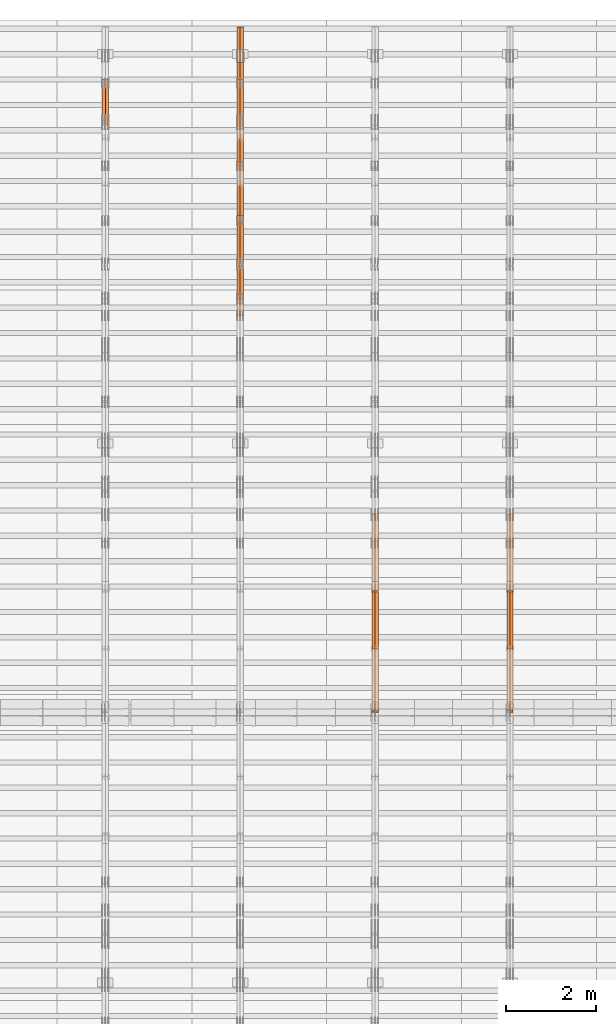
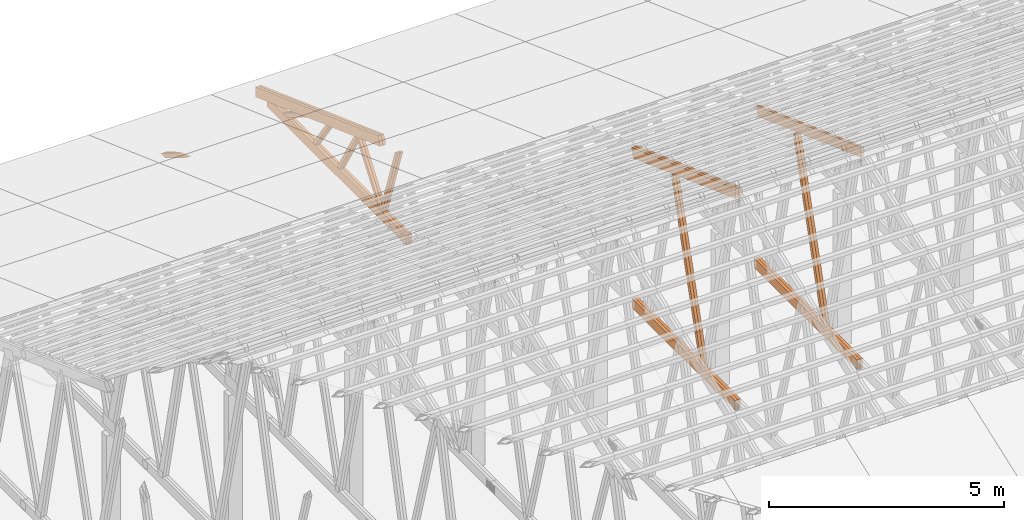
# One storey, part 37 of 189: 27 proxies.
"""IFC2X3 building model written with IfcOpenShell, lengths in millimetres."""

from ifc_helpers import new_model, entity, si_unit, converted_unit, derived_unit, direction, frame, origin, origin_2d_with_axis, place, context, subcontext, project, spatial, polyline, rectangle, outline, extrude, source, transform, mapped, material, type_object, type_shapes, element, save


model = new_model("IFC2X3")

# Units and contexts
model_context = context("Model", 3, precision=0.01, world=origin(), true_north=direction((6.12303176911189e-17, 1.0)))
body_context = subcontext(model_context, "Body", "Model", "MODEL_VIEW")
ifc_project = project(units=[si_unit("LENGTHUNIT", "METRE", prefix="MILLI"), si_unit("AREAUNIT", "SQUARE_METRE"), si_unit("VOLUMEUNIT", "CUBIC_METRE"), converted_unit("PLANEANGLEUNIT", "DEGREE", entity("IfcRatioMeasure", 0.0174532925199433), si_unit("PLANEANGLEUNIT", "RADIAN"), dimensions=[0, 0, 0, 0, 0, 0, 0]), si_unit("MASSUNIT", "GRAM", prefix="KILO"), derived_unit("MASSDENSITYUNIT", [(si_unit("MASSUNIT", "GRAM", prefix="KILO"), 1), (si_unit("LENGTHUNIT", "METRE"), -3)]), si_unit("TIMEUNIT", "SECOND"), si_unit("FREQUENCYUNIT", "HERTZ"), si_unit("THERMODYNAMICTEMPERATUREUNIT", "DEGREE_CELSIUS"), derived_unit("THERMALTRANSMITTANCEUNIT", [(si_unit("MASSUNIT", "GRAM", prefix="KILO"), 1), (si_unit("THERMODYNAMICTEMPERATUREUNIT", "KELVIN"), -1), (si_unit("TIMEUNIT", "SECOND"), -3)]), derived_unit("VOLUMETRICFLOWRATEUNIT", [(si_unit("LENGTHUNIT", "METRE"), 3), (si_unit("TIMEUNIT", "SECOND"), -1)]), si_unit("ELECTRICCURRENTUNIT", "AMPERE"), si_unit("ELECTRICVOLTAGEUNIT", "VOLT"), si_unit("POWERUNIT", "WATT"), si_unit("FORCEUNIT", "NEWTON"), si_unit("ILLUMINANCEUNIT", "LUX"), si_unit("LUMINOUSFLUXUNIT", "LUMEN"), si_unit("LUMINOUSINTENSITYUNIT", "CANDELA"), derived_unit("USERDEFINED", [(si_unit("MASSUNIT", "GRAM", prefix="KILO"), -1), (si_unit("LENGTHUNIT", "METRE"), -2), (si_unit("TIMEUNIT", "SECOND"), 3), (si_unit("LUMINOUSFLUXUNIT", "LUMEN"), 1)]), derived_unit("LINEARVELOCITYUNIT", [(si_unit("LENGTHUNIT", "METRE"), 1), (si_unit("TIMEUNIT", "SECOND"), -1)]), si_unit("PRESSUREUNIT", "PASCAL"), derived_unit("USERDEFINED", [(si_unit("LENGTHUNIT", "METRE"), -2), (si_unit("MASSUNIT", "GRAM", prefix="KILO"), 1), (si_unit("TIMEUNIT", "SECOND"), -2)])], contexts=[model_context])

# Site, building, storey
site_placement = place(None, origin())
site = spatial("IfcSite", under=ifc_project, at=site_placement, CompositionType="ELEMENT")
building_placement = place(site_placement, origin())
building = spatial("IfcBuilding", under=site, at=building_placement, CompositionType="ELEMENT")
storey_placement = place(building_placement, origin())
storey = spatial("IfcBuildingStorey", under=building, at=storey_placement, Name="Default", CompositionType="ELEMENT", Elevation=0.0)

# Proxies
ifc_material_1 = material(Name="IfcSurfaceStyle #99818")
building_element_proxy_type_1 = type_object("IfcBuildingElementProxyType", Name="T1-W6 99816", PredefinedType="NOTDEFINED", material=ifc_material_1)
shared_shape_1 = source(origin(), body_context, "Body", "SweptSolid", [
    extrude(outline(polyline([(-2668.68989660745, -47.5002238228721), (1800.72567700045, -47.5002238228721), (1797.68490303083, 0.000158637170537834), (1711.12272493628, 47.5001445042868), (-2640.84340836012, 47.5001445042868), (-2668.68989660745, -47.5002238228721)])), frame((1800.7257704503, 47.5001445042868, 0.0), z_axis=(0.0, 0.0, 1.0), x_axis=(-1.0, 0.0, 0.0)), (0.0, 0.0, 1.0), 69.9999999999997),
])
type_shapes(building_element_proxy_type_1, [shared_shape_1])
proxy_1_placement = place(building_placement, frame((18300.0, 17516.8749791841, 4507.23620831254), z_axis=(-1.0, 0.0, 0.0), x_axis=(0.0, -0.281285983104611, -0.959623986626466)))
element("IfcBuildingElementProxy", 1, at=proxy_1_placement, inside=storey, type_object=building_element_proxy_type_1, material=ifc_material_1, Name="T1-W6", context=body_context, shape_type="MappedRepresentation", body=[
    mapped(shared_shape_1, transform((0.0, 0.0, 0.0), scale=1.0)),
])
ifc_material_2 = material(Name="IfcSurfaceStyle #99752")
building_element_proxy_type_2 = type_object("IfcBuildingElementProxyType", Name="T1-W6 99750", PredefinedType="NOTDEFINED", material=ifc_material_2)
shared_shape_2 = source(origin(), body_context, "Body", "SweptSolid", [
    extrude(outline(polyline([(-2668.68989660745, -47.5002238228721), (1800.72567700045, -47.5002238228721), (1797.68490303083, 0.000158637170537834), (1711.12272493628, 47.5001445042868), (-2640.84340836012, 47.5001445042868), (-2668.68989660745, -47.5002238228721)])), frame((1800.7257704503, 47.5001445042868, 0.0), z_axis=(0.0, 0.0, 1.0), x_axis=(-1.0, 0.0, 0.0)), (0.0, 0.0, 1.0), 69.9999999999997),
])
type_shapes(building_element_proxy_type_2, [shared_shape_2])
proxy_2_placement = place(building_placement, frame((18230.0, 17516.8749791841, 4507.23620831254), z_axis=(-1.0, 0.0, 0.0), x_axis=(0.0, -0.281285983104611, -0.959623986626466)))
element("IfcBuildingElementProxy", 2, at=proxy_2_placement, inside=storey, type_object=building_element_proxy_type_2, material=ifc_material_2, Name="T1-W6", context=body_context, shape_type="MappedRepresentation", body=[
    mapped(shared_shape_2, transform((0.0, 0.0, 0.0), scale=1.0)),
])
ifc_material_3 = material(Name="IfcSurfaceStyle #96044")
building_element_proxy_type_3 = type_object("IfcBuildingElementProxyType", Name="T1-B5 96042", PredefinedType="NOTDEFINED", material=ifc_material_3)
shared_shape_3 = source(origin(), body_context, "Body", "SweptSolid", [
    extrude(rectangle(XDim=4381.5, YDim=245.000000000001, at=origin_2d_with_axis()), frame((2190.75, 122.5, 0.0), z_axis=(0.0, 0.0, 1.0), x_axis=(-1.0, 0.0, 0.0)), (0.0, 0.0, 1.0), 69.9999999999997),
])
type_shapes(building_element_proxy_type_3, [shared_shape_3])
proxy_3_placement = place(building_placement, frame((18300.0, 14780.2587890625, 245.0), z_axis=(-1.0, 0.0, 0.0), x_axis=(0.0, 1.0, 0.0)))
element("IfcBuildingElementProxy", 3, at=proxy_3_placement, inside=storey, type_object=building_element_proxy_type_3, material=ifc_material_3, Name="T1-B5", context=body_context, shape_type="MappedRepresentation", body=[
    mapped(shared_shape_3, transform((0.0, 0.0, 0.0), scale=1.0)),
])
ifc_material_4 = material(Name="IfcSurfaceStyle #95987")
building_element_proxy_type_4 = type_object("IfcBuildingElementProxyType", Name="T1-B5 95985", PredefinedType="NOTDEFINED", material=ifc_material_4)
shared_shape_4 = source(origin(), body_context, "Body", "SweptSolid", [
    extrude(rectangle(XDim=4381.5, YDim=245.000000000001, at=origin_2d_with_axis()), frame((2190.75, 122.5, 0.0), z_axis=(0.0, 0.0, 1.0), x_axis=(-1.0, 0.0, 0.0)), (0.0, 0.0, 1.0), 69.9999999999997),
])
type_shapes(building_element_proxy_type_4, [shared_shape_4])
proxy_4_placement = place(building_placement, frame((18230.0, 14780.2587890625, 245.0), z_axis=(-1.0, 0.0, 0.0), x_axis=(0.0, 1.0, 0.0)))
element("IfcBuildingElementProxy", 4, at=proxy_4_placement, inside=storey, type_object=building_element_proxy_type_4, material=ifc_material_4, Name="T1-B5", context=body_context, shape_type="MappedRepresentation", body=[
    mapped(shared_shape_4, transform((0.0, 0.0, 0.0), scale=1.0)),
])
ifc_material_5 = material(Name="IfcSurfaceStyle #95228")
building_element_proxy_type_5 = type_object("IfcBuildingElementProxyType", Name="T1-T3 95226", PredefinedType="NOTDEFINED", material=ifc_material_5)
shared_shape_5 = source(origin(), body_context, "Body", "SweptSolid", [
    extrude(outline(polyline([(-2386.23525922045, -122.500022994835), (2341.64890001386, -122.500022994835), (2341.64888416412, 122.500022994835), (-2297.06252495753, 122.500022994835), (-2386.23525922045, -122.500022994835)])), frame((2341.64890001386, 122.500051926629, 0.0), z_axis=(0.0, 0.0, 1.0), x_axis=(-1.0, 0.0, 0.0)), (0.0, 0.0, 1.0), 69.9999999999997),
])
type_shapes(building_element_proxy_type_5, [shared_shape_5])
proxy_5_placement = place(building_placement, frame((18300.0, 19108.9628956236, 3921.30465489208), z_axis=(-1.0, 0.0, 0.0), x_axis=(0.0, -0.939692620785908, 0.342020143325669)))
element("IfcBuildingElementProxy", 5, at=proxy_5_placement, inside=storey, type_object=building_element_proxy_type_5, material=ifc_material_5, Name="T1-T3", context=body_context, shape_type="MappedRepresentation", body=[
    mapped(shared_shape_5, transform((0.0, 0.0, 0.0), scale=1.0)),
])
ifc_material_6 = material(Name="IfcSurfaceStyle #84028")
building_element_proxy_type_6 = type_object("IfcBuildingElementProxyType", Name="T1-W6 84026", PredefinedType="NOTDEFINED", material=ifc_material_6)
shared_shape_6 = source(origin(), body_context, "Body", "SweptSolid", [
    extrude(outline(polyline([(-2668.68989660745, -47.5002238228721), (1800.72567700045, -47.5002238228721), (1797.68490303083, 0.000158637170537834), (1711.12272493628, 47.5001445042868), (-2640.84340836012, 47.5001445042868), (-2668.68989660745, -47.5002238228721)])), frame((1800.7257704503, 47.5001445042868, 0.0), z_axis=(0.0, 0.0, 1.0), x_axis=(-1.0, 0.0, 0.0)), (0.0, 0.0, 1.0), 69.9999999999997),
])
type_shapes(building_element_proxy_type_6, [shared_shape_6])
proxy_6_placement = place(building_placement, frame((15300.0, 17516.8749791841, 4507.23620831254), z_axis=(-1.0, 0.0, 0.0), x_axis=(0.0, -0.281285983104611, -0.959623986626466)))
element("IfcBuildingElementProxy", 6, at=proxy_6_placement, inside=storey, type_object=building_element_proxy_type_6, material=ifc_material_6, Name="T1-W6", context=body_context, shape_type="MappedRepresentation", body=[
    mapped(shared_shape_6, transform((0.0, 0.0, 0.0), scale=1.0)),
])
ifc_material_7 = material(Name="IfcSurfaceStyle #83962")
building_element_proxy_type_7 = type_object("IfcBuildingElementProxyType", Name="T1-W6 83960", PredefinedType="NOTDEFINED", material=ifc_material_7)
shared_shape_7 = source(origin(), body_context, "Body", "SweptSolid", [
    extrude(outline(polyline([(-2668.68989660745, -47.5002238228721), (1800.72567700045, -47.5002238228721), (1797.68490303083, 0.000158637170537834), (1711.12272493628, 47.5001445042868), (-2640.84340836012, 47.5001445042868), (-2668.68989660745, -47.5002238228721)])), frame((1800.7257704503, 47.5001445042868, 0.0), z_axis=(0.0, 0.0, 1.0), x_axis=(-1.0, 0.0, 0.0)), (0.0, 0.0, 1.0), 69.9999999999997),
])
type_shapes(building_element_proxy_type_7, [shared_shape_7])
proxy_7_placement = place(building_placement, frame((15230.0, 17516.8749791841, 4507.23620831254), z_axis=(-1.0, 0.0, 0.0), x_axis=(0.0, -0.281285983104611, -0.959623986626466)))
element("IfcBuildingElementProxy", 7, at=proxy_7_placement, inside=storey, type_object=building_element_proxy_type_7, material=ifc_material_7, Name="T1-W6", context=body_context, shape_type="MappedRepresentation", body=[
    mapped(shared_shape_7, transform((0.0, 0.0, 0.0), scale=1.0)),
])
ifc_material_8 = material(Name="IfcSurfaceStyle #80254")
building_element_proxy_type_8 = type_object("IfcBuildingElementProxyType", Name="T1-B5 80252", PredefinedType="NOTDEFINED", material=ifc_material_8)
shared_shape_8 = source(origin(), body_context, "Body", "SweptSolid", [
    extrude(rectangle(XDim=4381.5, YDim=245.000000000001, at=origin_2d_with_axis()), frame((2190.75, 122.5, 0.0), z_axis=(0.0, 0.0, 1.0), x_axis=(-1.0, 0.0, 0.0)), (0.0, 0.0, 1.0), 69.9999999999997),
])
type_shapes(building_element_proxy_type_8, [shared_shape_8])
proxy_8_placement = place(building_placement, frame((15300.0, 14780.2587890625, 245.0), z_axis=(-1.0, 0.0, 0.0), x_axis=(0.0, 1.0, 0.0)))
element("IfcBuildingElementProxy", 8, at=proxy_8_placement, inside=storey, type_object=building_element_proxy_type_8, material=ifc_material_8, Name="T1-B5", context=body_context, shape_type="MappedRepresentation", body=[
    mapped(shared_shape_8, transform((0.0, 0.0, 0.0), scale=1.0)),
])
ifc_material_9 = material(Name="IfcSurfaceStyle #80197")
building_element_proxy_type_9 = type_object("IfcBuildingElementProxyType", Name="T1-B5 80195", PredefinedType="NOTDEFINED", material=ifc_material_9)
shared_shape_9 = source(origin(), body_context, "Body", "SweptSolid", [
    extrude(rectangle(XDim=4381.5, YDim=245.000000000001, at=origin_2d_with_axis()), frame((2190.75, 122.5, 0.0), z_axis=(0.0, 0.0, 1.0), x_axis=(-1.0, 0.0, 0.0)), (0.0, 0.0, 1.0), 69.9999999999997),
])
type_shapes(building_element_proxy_type_9, [shared_shape_9])
proxy_9_placement = place(building_placement, frame((15230.0, 14780.2587890625, 245.0), z_axis=(-1.0, 0.0, 0.0), x_axis=(0.0, 1.0, 0.0)))
element("IfcBuildingElementProxy", 9, at=proxy_9_placement, inside=storey, type_object=building_element_proxy_type_9, material=ifc_material_9, Name="T1-B5", context=body_context, shape_type="MappedRepresentation", body=[
    mapped(shared_shape_9, transform((0.0, 0.0, 0.0), scale=1.0)),
])
ifc_material_10 = material(Name="IfcSurfaceStyle #79438")
building_element_proxy_type_10 = type_object("IfcBuildingElementProxyType", Name="T1-T3 79436", PredefinedType="NOTDEFINED", material=ifc_material_10)
shared_shape_10 = source(origin(), body_context, "Body", "SweptSolid", [
    extrude(outline(polyline([(-2386.23525922045, -122.500022994835), (2341.64890001386, -122.500022994835), (2341.64888416412, 122.500022994835), (-2297.06252495753, 122.500022994835), (-2386.23525922045, -122.500022994835)])), frame((2341.64890001386, 122.500051926629, 0.0), z_axis=(0.0, 0.0, 1.0), x_axis=(-1.0, 0.0, 0.0)), (0.0, 0.0, 1.0), 69.9999999999997),
])
type_shapes(building_element_proxy_type_10, [shared_shape_10])
proxy_10_placement = place(building_placement, frame((15300.0, 19108.9628956236, 3921.30465489208), z_axis=(-1.0, 0.0, 0.0), x_axis=(0.0, -0.939692620785908, 0.342020143325669)))
element("IfcBuildingElementProxy", 10, at=proxy_10_placement, inside=storey, type_object=building_element_proxy_type_10, material=ifc_material_10, Name="T1-T3", context=body_context, shape_type="MappedRepresentation", body=[
    mapped(shared_shape_10, transform((0.0, 0.0, 0.0), scale=1.0)),
])
ifc_material_11 = material(Name="IfcSurfaceStyle #79381")
building_element_proxy_type_11 = type_object("IfcBuildingElementProxyType", Name="T1-T3 79379", PredefinedType="NOTDEFINED", material=ifc_material_11)
shared_shape_11 = source(origin(), body_context, "Body", "SweptSolid", [
    extrude(outline(polyline([(-2386.23525922045, -122.500022994835), (2341.64890001386, -122.500022994835), (2341.64888416412, 122.500022994835), (-2297.06252495753, 122.500022994835), (-2386.23525922045, -122.500022994835)])), frame((2341.64890001386, 122.500051926629, 0.0), z_axis=(0.0, 0.0, 1.0), x_axis=(-1.0, 0.0, 0.0)), (0.0, 0.0, 1.0), 69.9999999999997),
])
type_shapes(building_element_proxy_type_11, [shared_shape_11])
proxy_11_placement = place(building_placement, frame((15230.0, 19108.9628956236, 3921.30465489208), z_axis=(-1.0, 0.0, 0.0), x_axis=(0.0, -0.939692620785908, 0.342020143325669)))
element("IfcBuildingElementProxy", 11, at=proxy_11_placement, inside=storey, type_object=building_element_proxy_type_11, material=ifc_material_11, Name="T1-T3", context=body_context, shape_type="MappedRepresentation", body=[
    mapped(shared_shape_11, transform((0.0, 0.0, 0.0), scale=1.0)),
])
ifc_material_12 = material(Name="IfcSurfaceStyle #66390")
building_element_proxy_type_12 = type_object("IfcBuildingElementProxyType", Name="T1-W9 66388", PredefinedType="NOTDEFINED", material=ifc_material_12)
shared_shape_12 = source(origin(), body_context, "Body", "SweptSolid", [
    extrude(outline(polyline([(-1151.44310138162, -47.5000079487596), (776.329826327547, -47.5000079487596), (809.267611644053, -8.1966354137375e-07), (793.242530238244, 47.5000083585914), (-1227.39686682822, 47.5000083585914), (-1151.44310138162, -47.5000079487596)])), frame((809.267685789073, 47.5000083585914, 0.0), z_axis=(0.0, 0.0, 1.0), x_axis=(-1.0, 0.0, 0.0)), (0.0, 0.0, 1.0), 69.9999999999999),
])
type_shapes(building_element_proxy_type_12, [shared_shape_12])
proxy_12_placement = place(building_placement, frame((12300.0, 24600.2198992919, 229.815691184017), z_axis=(-1.0, 0.0, 0.0), x_axis=(0.0, -0.31966811847134, 0.947529574226047)))
element("IfcBuildingElementProxy", 12, at=proxy_12_placement, inside=storey, type_object=building_element_proxy_type_12, material=ifc_material_12, Name="T1-W9", context=body_context, shape_type="MappedRepresentation", body=[
    mapped(shared_shape_12, transform((0.0, 0.0, 0.0), scale=1.0)),
])
ifc_material_13 = material(Name="IfcSurfaceStyle #66324")
building_element_proxy_type_13 = type_object("IfcBuildingElementProxyType", Name="T1-W9 66322", PredefinedType="NOTDEFINED", material=ifc_material_13)
shared_shape_13 = source(origin(), body_context, "Body", "SweptSolid", [
    extrude(outline(polyline([(-1151.44310138162, -47.5000079487596), (776.329826327547, -47.5000079487596), (809.267611644053, -8.1966354137375e-07), (793.242530238244, 47.5000083585914), (-1227.39686682822, 47.5000083585914), (-1151.44310138162, -47.5000079487596)])), frame((809.267685789073, 47.5000083585914, 0.0), z_axis=(0.0, 0.0, 1.0), x_axis=(-1.0, 0.0, 0.0)), (0.0, 0.0, 1.0), 69.9999999999999),
])
type_shapes(building_element_proxy_type_13, [shared_shape_13])
proxy_13_placement = place(building_placement, frame((12230.0, 24600.2198992919, 229.815691184017), z_axis=(-1.0, 0.0, 0.0), x_axis=(0.0, -0.31966811847134, 0.947529574226047)))
element("IfcBuildingElementProxy", 13, at=proxy_13_placement, inside=storey, type_object=building_element_proxy_type_13, material=ifc_material_13, Name="T1-W9", context=body_context, shape_type="MappedRepresentation", body=[
    mapped(shared_shape_13, transform((0.0, 0.0, 0.0), scale=1.0)),
])
ifc_material_14 = material(Name="IfcSurfaceStyle #66126")
building_element_proxy_type_14 = type_object("IfcBuildingElementProxyType", Name="T1-W10 66124", PredefinedType="NOTDEFINED", material=ifc_material_14)
shared_shape_14 = source(origin(), body_context, "Body", "SweptSolid", [
    extrude(outline(polyline([(-993.240970354386, -47.5000757607337), (635.890952815036, -47.5000757607337), (650.068145237537, -1.47580554758164e-05), (629.921374092803, 47.5000831397614), (-922.639501790989, 47.5000831397614), (-993.240970354386, -47.5000757607337)])), frame((650.068173419645, 47.5002811208496, 0.0), z_axis=(0.0, 0.0, 1.0), x_axis=(-1.0, 0.0, 0.0)), (0.0, 0.0, 1.0), 69.9999999999999),
])
type_shapes(building_element_proxy_type_14, [shared_shape_14])
proxy_14_placement = place(building_placement, frame((12300.0, 25701.688098798, 1507.2920009025), z_axis=(-1.0, 0.0, 0.0), x_axis=(0.0, -0.596486092002004, -0.802623412347395)))
element("IfcBuildingElementProxy", 14, at=proxy_14_placement, inside=storey, type_object=building_element_proxy_type_14, material=ifc_material_14, Name="T1-W10", context=body_context, shape_type="MappedRepresentation", body=[
    mapped(shared_shape_14, transform((0.0, 0.0, 0.0), scale=1.0)),
])
ifc_material_15 = material(Name="IfcSurfaceStyle #66060")
building_element_proxy_type_15 = type_object("IfcBuildingElementProxyType", Name="T1-W10 66058", PredefinedType="NOTDEFINED", material=ifc_material_15)
shared_shape_15 = source(origin(), body_context, "Body", "SweptSolid", [
    extrude(outline(polyline([(-993.240970354386, -47.5000757607337), (635.890952815036, -47.5000757607337), (650.068145237537, -1.47580554758164e-05), (629.921374092803, 47.5000831397614), (-922.639501790989, 47.5000831397614), (-993.240970354386, -47.5000757607337)])), frame((650.068173419645, 47.5002811208496, 0.0), z_axis=(0.0, 0.0, 1.0), x_axis=(-1.0, 0.0, 0.0)), (0.0, 0.0, 1.0), 69.9999999999999),
])
type_shapes(building_element_proxy_type_15, [shared_shape_15])
proxy_15_placement = place(building_placement, frame((12230.0, 25701.688098798, 1507.2920009025), z_axis=(-1.0, 0.0, 0.0), x_axis=(0.0, -0.596486092002004, -0.802623412347395)))
element("IfcBuildingElementProxy", 15, at=proxy_15_placement, inside=storey, type_object=building_element_proxy_type_15, material=ifc_material_15, Name="T1-W10", context=body_context, shape_type="MappedRepresentation", body=[
    mapped(shared_shape_15, transform((0.0, 0.0, 0.0), scale=1.0)),
])
ifc_material_16 = material(Name="IfcSurfaceStyle #65862")
building_element_proxy_type_16 = type_object("IfcBuildingElementProxyType", Name="T1-W11 65860", PredefinedType="NOTDEFINED", material=ifc_material_16)
shared_shape_16 = source(origin(), body_context, "Body", "SweptSolid", [
    extrude(outline(polyline([(-809.410890003667, -47.5000077306544), (561.624013869753, -47.5000077306544), (599.944137054867, -7.52294285037536e-05), (572.078784657538, 47.5000453453687), (-924.236045578491, 47.5000453453687), (-809.410890003667, -47.5000077306544)])), frame((599.944137054867, 47.5000453453687, 0.0), z_axis=(0.0, 0.0, 1.0), x_axis=(-1.0, 0.0, 0.0)), (0.0, 0.0, 1.0), 69.9999999999999),
])
type_shapes(building_element_proxy_type_16, [shared_shape_16])
proxy_16_placement = place(building_placement, frame((12300.0, 26434.7921369083, 220.965133687368), z_axis=(-1.0, 0.0, 0.0), x_axis=(0.0, -0.505995901100603, 0.862535882192381)))
element("IfcBuildingElementProxy", 16, at=proxy_16_placement, inside=storey, type_object=building_element_proxy_type_16, material=ifc_material_16, Name="T1-W11", context=body_context, shape_type="MappedRepresentation", body=[
    mapped(shared_shape_16, transform((0.0, 0.0, 0.0), scale=1.0)),
])
ifc_material_17 = material(Name="IfcSurfaceStyle #65796")
building_element_proxy_type_17 = type_object("IfcBuildingElementProxyType", Name="T1-W11 65794", PredefinedType="NOTDEFINED", material=ifc_material_17)
shared_shape_17 = source(origin(), body_context, "Body", "SweptSolid", [
    extrude(outline(polyline([(-809.410890003667, -47.5000077306544), (561.624013869753, -47.5000077306544), (599.944137054867, -7.52294285037536e-05), (572.078784657538, 47.5000453453687), (-924.236045578491, 47.5000453453687), (-809.410890003667, -47.5000077306544)])), frame((599.944137054867, 47.5000453453687, 0.0), z_axis=(0.0, 0.0, 1.0), x_axis=(-1.0, 0.0, 0.0)), (0.0, 0.0, 1.0), 69.9999999999999),
])
type_shapes(building_element_proxy_type_17, [shared_shape_17])
proxy_17_placement = place(building_placement, frame((12230.0, 26434.7921369083, 220.965133687368), z_axis=(-1.0, 0.0, 0.0), x_axis=(0.0, -0.505995901100603, 0.862535882192381)))
element("IfcBuildingElementProxy", 17, at=proxy_17_placement, inside=storey, type_object=building_element_proxy_type_17, material=ifc_material_17, Name="T1-W11", context=body_context, shape_type="MappedRepresentation", body=[
    mapped(shared_shape_17, transform((0.0, 0.0, 0.0), scale=1.0)),
])
ifc_material_18 = material(Name="IfcSurfaceStyle #65334")
building_element_proxy_type_18 = type_object("IfcBuildingElementProxyType", Name="T1-W13 65332", PredefinedType="NOTDEFINED", material=ifc_material_18)
shared_shape_18 = source(origin(), body_context, "Body", "SweptSolid", [
    extrude(outline(polyline([(-527.416466728212, -47.5000272833949), (387.658053197984, -47.5000272833949), (418.029495084182, -7.96824534414764e-06), (384.779443025059, 47.5000312675175), (-663.050524579013, 47.5000312675176), (-527.416466728212, -47.5000272833949)])), frame((418.029495084182, 47.5000671658844, 0.0), z_axis=(0.0, 0.0, 1.0), x_axis=(-1.0, 0.0, 0.0)), (0.0, 0.0, 1.0), 69.9999999999999),
])
type_shapes(building_element_proxy_type_18, [shared_shape_18])
proxy_18_placement = place(building_placement, frame((12300.0, 27471.0085508293, 217.760482033818), z_axis=(-1.0, 0.0, 0.0), x_axis=(0.0, -0.573462629043498, 0.819231721242848)))
element("IfcBuildingElementProxy", 18, at=proxy_18_placement, inside=storey, type_object=building_element_proxy_type_18, material=ifc_material_18, Name="T1-W13", context=body_context, shape_type="MappedRepresentation", body=[
    mapped(shared_shape_18, transform((0.0, 0.0, 0.0), scale=1.0)),
])
ifc_material_19 = material(Name="IfcSurfaceStyle #65268")
building_element_proxy_type_19 = type_object("IfcBuildingElementProxyType", Name="T1-W13 65266", PredefinedType="NOTDEFINED", material=ifc_material_19)
shared_shape_19 = source(origin(), body_context, "Body", "SweptSolid", [
    extrude(outline(polyline([(-527.416466728212, -47.5000272833949), (387.658053197984, -47.5000272833949), (418.029495084182, -7.96824534414764e-06), (384.779443025059, 47.5000312675175), (-663.050524579013, 47.5000312675176), (-527.416466728212, -47.5000272833949)])), frame((418.029495084182, 47.5000671658844, 0.0), z_axis=(0.0, 0.0, 1.0), x_axis=(-1.0, 0.0, 0.0)), (0.0, 0.0, 1.0), 69.9999999999999),
])
type_shapes(building_element_proxy_type_19, [shared_shape_19])
proxy_19_placement = place(building_placement, frame((12230.0, 27471.0085508293, 217.760482033818), z_axis=(-1.0, 0.0, 0.0), x_axis=(0.0, -0.573462629043498, 0.819231721242848)))
element("IfcBuildingElementProxy", 19, at=proxy_19_placement, inside=storey, type_object=building_element_proxy_type_19, material=ifc_material_19, Name="T1-W13", context=body_context, shape_type="MappedRepresentation", body=[
    mapped(shared_shape_19, transform((0.0, 0.0, 0.0), scale=1.0)),
])
ifc_material_20 = material(Name="IfcSurfaceStyle #64824")
building_element_proxy_type_20 = type_object("IfcBuildingElementProxyType", Name="T1-W12 64822", PredefinedType="NOTDEFINED", material=ifc_material_20)
shared_shape_20 = source(origin(), body_context, "Body", "SweptSolid", [
    extrude(outline(polyline([(-176.861423449428, -47.5000064161489), (503.856777435794, -47.5000064161489), (344.893496040196, 47.5000064161489), (-671.888850026563, 47.5000064161488), (-176.861423449428, -47.5000064161489)])), frame((503.856799890979, 47.5000428456028, 0.0), z_axis=(0.0, 0.0, 1.0), x_axis=(-1.0, 0.0, 0.0)), (0.0, 0.0, 1.0), 69.9999999999999),
])
type_shapes(building_element_proxy_type_20, [shared_shape_20])
proxy_20_placement = place(building_placement, frame((12300.0, 28785.6842742264, 163.452728724015), z_axis=(-1.0, 0.0, 0.0), x_axis=(0.0, -0.858392121304013, 0.51299411895576)))
element("IfcBuildingElementProxy", 20, at=proxy_20_placement, inside=storey, type_object=building_element_proxy_type_20, material=ifc_material_20, Name="T1-W12", context=body_context, shape_type="MappedRepresentation", body=[
    mapped(shared_shape_20, transform((0.0, 0.0, 0.0), scale=1.0)),
])
ifc_material_21 = material(Name="IfcSurfaceStyle #64767")
building_element_proxy_type_21 = type_object("IfcBuildingElementProxyType", Name="T1-W12 64765", PredefinedType="NOTDEFINED", material=ifc_material_21)
shared_shape_21 = source(origin(), body_context, "Body", "SweptSolid", [
    extrude(outline(polyline([(-176.861423449428, -47.5000064161489), (503.856777435794, -47.5000064161489), (344.893496040196, 47.5000064161489), (-671.888850026563, 47.5000064161488), (-176.861423449428, -47.5000064161489)])), frame((503.856799890979, 47.5000428456028, 0.0), z_axis=(0.0, 0.0, 1.0), x_axis=(-1.0, 0.0, 0.0)), (0.0, 0.0, 1.0), 69.9999999999999),
])
type_shapes(building_element_proxy_type_21, [shared_shape_21])
proxy_21_placement = place(building_placement, frame((12230.0, 28785.6842742264, 163.452728724015), z_axis=(-1.0, 0.0, 0.0), x_axis=(0.0, -0.858392121304013, 0.51299411895576)))
element("IfcBuildingElementProxy", 21, at=proxy_21_placement, inside=storey, type_object=building_element_proxy_type_21, material=ifc_material_21, Name="T1-W12", context=body_context, shape_type="MappedRepresentation", body=[
    mapped(shared_shape_21, transform((0.0, 0.0, 0.0), scale=1.0)),
])
ifc_material_22 = material(Name="IfcSurfaceStyle #64710")
building_element_proxy_type_22 = type_object("IfcBuildingElementProxyType", Name="T1-B1 64708", PredefinedType="NOTDEFINED", material=ifc_material_22)
shared_shape_22 = source(origin(), body_context, "Body", "SweptSolid", [
    extrude(outline(polyline([(-2430.09461669922, -125.855288696288), (3499.90538330078, -125.855288696288), (3499.90538330078, 119.144711303711), (-2139.62153320312, 119.144711303711), (-2430.09461669922, 13.4211547851552), (-2430.09461669922, -125.855288696288)])), frame((3499.90538330078, 119.144711303711, 0.0), z_axis=(0.0, 0.0, 1.0), x_axis=(-1.0, 0.0, 0.0)), (0.0, 0.0, 1.0), 69.9999999999996),
])
type_shapes(building_element_proxy_type_22, [shared_shape_22])
proxy_22_placement = place(building_placement, frame((12300.0, 23570.0, 245.0), z_axis=(-1.0, 0.0, 0.0), x_axis=(0.0, 1.0, 0.0)))
element("IfcBuildingElementProxy", 22, at=proxy_22_placement, inside=storey, type_object=building_element_proxy_type_22, material=ifc_material_22, Name="T1-B1", context=body_context, shape_type="MappedRepresentation", body=[
    mapped(shared_shape_22, transform((0.0, 0.0, 0.0), scale=1.0)),
])
ifc_material_23 = material(Name="IfcSurfaceStyle #64644")
building_element_proxy_type_23 = type_object("IfcBuildingElementProxyType", Name="T1-B1 64642", PredefinedType="NOTDEFINED", material=ifc_material_23)
shared_shape_23 = source(origin(), body_context, "Body", "SweptSolid", [
    extrude(outline(polyline([(-2430.09461669922, -125.855288696288), (3499.90538330078, -125.855288696288), (3499.90538330078, 119.144711303711), (-2139.62153320312, 119.144711303711), (-2430.09461669922, 13.4211547851552), (-2430.09461669922, -125.855288696288)])), frame((3499.90538330078, 119.144711303711, 0.0), z_axis=(0.0, 0.0, 1.0), x_axis=(-1.0, 0.0, 0.0)), (0.0, 0.0, 1.0), 69.9999999999996),
])
type_shapes(building_element_proxy_type_23, [shared_shape_23])
proxy_23_placement = place(building_placement, frame((12230.0, 23570.0, 245.0), z_axis=(-1.0, 0.0, 0.0), x_axis=(0.0, 1.0, 0.0)))
element("IfcBuildingElementProxy", 23, at=proxy_23_placement, inside=storey, type_object=building_element_proxy_type_23, material=ifc_material_23, Name="T1-B1", context=body_context, shape_type="MappedRepresentation", body=[
    mapped(shared_shape_23, transform((0.0, 0.0, 0.0), scale=1.0)),
])
ifc_material_24 = material(Name="IfcSurfaceStyle #63420")
building_element_proxy_type_24 = type_object("IfcBuildingElementProxyType", Name="T1-T2 63418", PredefinedType="NOTDEFINED", material=ifc_material_24)
shared_shape_24 = source(origin(), body_context, "Body", "SweptSolid", [
    extrude(outline(polyline([(-2807.70681121203, -122.500041939424), (2763.12044548192, -122.500041939424), (2852.29315104137, 122.500041939424), (-2807.70678531126, 122.500041939424), (-2807.70681121203, -122.500041939424)])), frame((2852.29315104137, 122.500041939424, 0.0), z_axis=(0.0, 0.0, 1.0), x_axis=(-1.0, 0.0, 0.0)), (0.0, 0.0, 1.0), 69.9999999999997),
])
type_shapes(building_element_proxy_type_24, [shared_shape_24])
proxy_24_placement = place(building_placement, frame((12300.0, 30000.0, -42.7086715698242), z_axis=(-1.0, 0.0, 0.0), x_axis=(0.0, -0.939692620785908, 0.342020143325669)))
element("IfcBuildingElementProxy", 24, at=proxy_24_placement, inside=storey, type_object=building_element_proxy_type_24, material=ifc_material_24, Name="T1-T2", context=body_context, shape_type="MappedRepresentation", body=[
    mapped(shared_shape_24, transform((0.0, 0.0, 0.0), scale=1.0)),
])
ifc_material_25 = material(Name="IfcSurfaceStyle #63363")
building_element_proxy_type_25 = type_object("IfcBuildingElementProxyType", Name="T1-T2 63361", PredefinedType="NOTDEFINED", material=ifc_material_25)
shared_shape_25 = source(origin(), body_context, "Body", "SweptSolid", [
    extrude(outline(polyline([(-2807.70681121203, -122.500041939424), (2763.12044548192, -122.500041939424), (2852.29315104137, 122.500041939424), (-2807.70678531126, 122.500041939424), (-2807.70681121203, -122.500041939424)])), frame((2852.29315104137, 122.500041939424, 0.0), z_axis=(0.0, 0.0, 1.0), x_axis=(-1.0, 0.0, 0.0)), (0.0, 0.0, 1.0), 69.9999999999997),
])
type_shapes(building_element_proxy_type_25, [shared_shape_25])
proxy_25_placement = place(building_placement, frame((12230.0, 30000.0, -42.7086715698242), z_axis=(-1.0, 0.0, 0.0), x_axis=(0.0, -0.939692620785908, 0.342020143325669)))
element("IfcBuildingElementProxy", 25, at=proxy_25_placement, inside=storey, type_object=building_element_proxy_type_25, material=ifc_material_25, Name="T1-T2", context=body_context, shape_type="MappedRepresentation", body=[
    mapped(shared_shape_25, transform((0.0, 0.0, 0.0), scale=1.0)),
])
ifc_material_26 = material(Name="IfcSurfaceStyle #49034")
building_element_proxy_type_26 = type_object("IfcBuildingElementProxyType", Name="T1-W12 49032", PredefinedType="NOTDEFINED", material=ifc_material_26)
shared_shape_26 = source(origin(), body_context, "Body", "SweptSolid", [
    extrude(outline(polyline([(-176.861423449428, -47.5000064161489), (503.856777435794, -47.5000064161489), (344.893496040196, 47.5000064161489), (-671.888850026563, 47.5000064161488), (-176.861423449428, -47.5000064161489)])), frame((503.856799890979, 47.5000428456028, 0.0), z_axis=(0.0, 0.0, 1.0), x_axis=(-1.0, 0.0, 0.0)), (0.0, 0.0, 1.0), 69.9999999999999),
])
type_shapes(building_element_proxy_type_26, [shared_shape_26])
proxy_26_placement = place(building_placement, frame((9300.0, 28785.6842742264, 163.452728724015), z_axis=(-1.0, 0.0, 0.0), x_axis=(0.0, -0.858392121304013, 0.51299411895576)))
element("IfcBuildingElementProxy", 26, at=proxy_26_placement, inside=storey, type_object=building_element_proxy_type_26, material=ifc_material_26, Name="T1-W12", context=body_context, shape_type="MappedRepresentation", body=[
    mapped(shared_shape_26, transform((0.0, 0.0, 0.0), scale=1.0)),
])
ifc_material_27 = material(Name="IfcSurfaceStyle #48977")
building_element_proxy_type_27 = type_object("IfcBuildingElementProxyType", Name="T1-W12 48975", PredefinedType="NOTDEFINED", material=ifc_material_27)
shared_shape_27 = source(origin(), body_context, "Body", "SweptSolid", [
    extrude(outline(polyline([(-176.861423449428, -47.5000064161489), (503.856777435794, -47.5000064161489), (344.893496040196, 47.5000064161489), (-671.888850026563, 47.5000064161488), (-176.861423449428, -47.5000064161489)])), frame((503.856799890979, 47.5000428456028, 0.0), z_axis=(0.0, 0.0, 1.0), x_axis=(-1.0, 0.0, 0.0)), (0.0, 0.0, 1.0), 69.9999999999999),
])
type_shapes(building_element_proxy_type_27, [shared_shape_27])
proxy_27_placement = place(building_placement, frame((9230.0, 28785.6842742264, 163.452728724015), z_axis=(-1.0, 0.0, 0.0), x_axis=(0.0, -0.858392121304013, 0.51299411895576)))
element("IfcBuildingElementProxy", 27, at=proxy_27_placement, inside=storey, type_object=building_element_proxy_type_27, material=ifc_material_27, Name="T1-W12", context=body_context, shape_type="MappedRepresentation", body=[
    mapped(shared_shape_27, transform((0.0, 0.0, 0.0), scale=1.0)),
])

save(model, "model.ifc")
